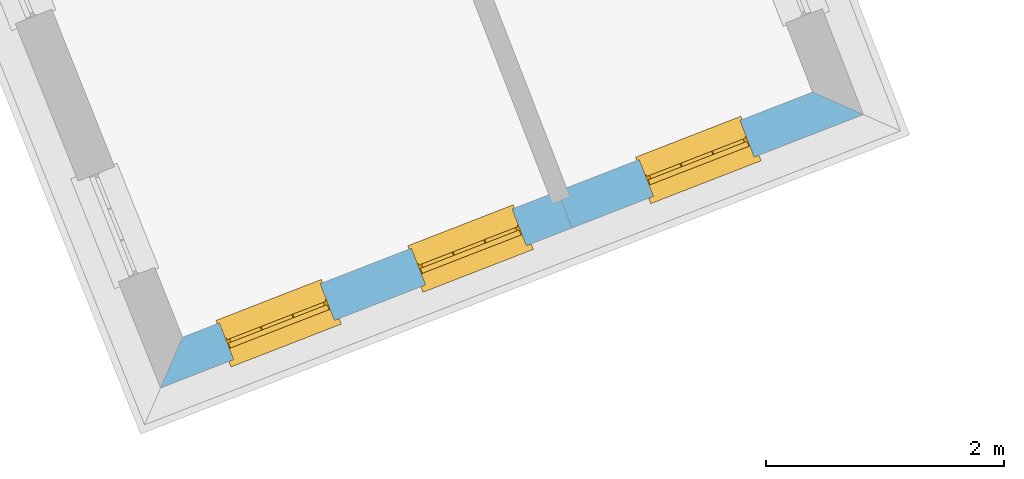
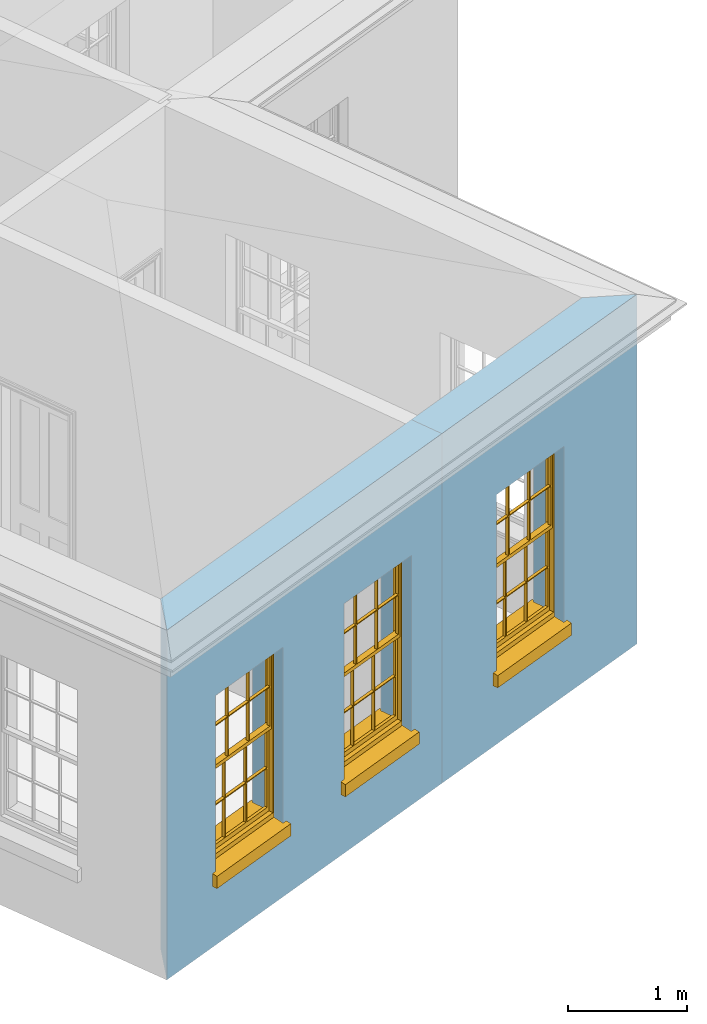
# One storey, part 3 of 11: 3 windows, 3 openings, plus 2 elements that do not belong to this part.
"""IFC2X3 building model written with IfcOpenShell, lengths in metres."""

from ifc_helpers import new_model, si_unit, frame, origin, place, context, subcontext, project, spatial, polyline, outline, extrude, faceted_brep, material, layer, layer_set, layer_usage, element, fill, save


model = new_model("IFC2X3")

# Units and contexts
model_context = context("Model", 3, world=origin())
body_context = subcontext(model_context, "Body", "Model", "MODEL_VIEW")
ifc_project = project(units=[si_unit("PLANEANGLEUNIT", "RADIAN"), si_unit("MASSUNIT", "GRAM", prefix="KILO"), si_unit("FORCEUNIT", "NEWTON", prefix="KILO"), si_unit("LENGTHUNIT", "METRE")], contexts=[model_context])

# Site, building, storey
site_placement = place(None, origin())
site = spatial("IfcSite", under=ifc_project, at=site_placement, CompositionType="ELEMENT")
building_placement = place(None, origin())
building = spatial("IfcBuilding", under=site, at=building_placement, Name="Building plot-3", CompositionType="ELEMENT")
storey_placement = place(None, frame((0.0, 0.0, 5.45)))
storey = spatial("IfcBuildingStorey", under=building, at=storey_placement, Name="Floor 1", CompositionType="ELEMENT", Elevation=5.45)

# Wall, openings, windows
ifc_material = material(Name="Masonry")
ifc_layer = layer(ifc_material, 0.33, ventilated=False)
ifc_layer_set = layer_set([ifc_layer], Name="My Wall")
ifc_layer_usage = layer_usage(ifc_layer_set, "AXIS2", "NEGATIVE", 0.08)
wall_1_placement = place(storey_placement, origin())
wall_1 = element("IfcWallStandardCase", 1, at=wall_1_placement, inside=storey, material=ifc_layer_usage, Name="exterior", context=body_context, shape_type="SweptSolid", body=[
    extrude(outline(polyline([(37.5567759813035, 41.9542826933014), (37.3715047734547, 41.5281179338397), (40.8267699200856, 42.8722782867018), (40.7071281618522, 43.1798264125078), (37.5567759813035, 41.9542826933014)])), origin(), (0.0, 0.0, 1.0), 3.6),
])
opening_1_placement = place(storey_placement, frame((0.0, 0.0, 0.75)))
opening_1 = element("IfcOpeningElement", 2, at=opening_1_placement, cuts=wall_1, Name="Opening", ObjectType="Opening", context=body_context, shape_type="SweptSolid", body=[
    extrude(outline(polyline([(37.9845234355629, 41.7665932305832), (38.8326106915735, 42.0965144426814), (38.7129689333401, 42.4040625684875), (37.8648816773295, 42.0741413563893), (37.9845234355629, 41.7665932305832)])), origin(), (0.0, 0.0, 1.0), 1.82),
])
opening_2_placement = place(storey_placement, frame((0.0, 0.0, 0.75)))
opening_2 = element("IfcOpeningElement", 3, at=opening_2_placement, cuts=wall_1, Name="Opening", ObjectType="Opening", context=body_context, shape_type="SweptSolid", body=[
    extrude(outline(polyline([(39.5966586732411, 42.3937428639628), (40.4447459292518, 42.723664076061), (40.3251041710184, 43.0312122018671), (39.4770169150077, 42.7012909897689), (39.5966586732411, 42.3937428639628)])), origin(), (0.0, 0.0, 1.0), 1.82),
])
window_1_placement = place(storey_placement, frame((37.8938857399315, 41.9995842349817, 0.75), z_axis=(0.0, 0.0, 1.0), x_axis=(0.848087256010636, 0.329921212098199, 0.0)))
window_1 = element("IfcWindow", 4, at=window_1_placement, inside=storey, Name="bedroom outside window", OverallHeight=1.82, OverallWidth=0.91, context=body_context, shape_type="Brep", held_by="IfcProductRepresentation", body=[
    faceted_brep([(0.033125, -0.105, 0.975209), (0.01, -0.105, 0.975209), (0.033125, -0.105, 1.376042), (0.876875, -0.105, 0.975209), (0.876875, -0.105, 1.376042), (0.9, -0.105, 0.975209), (0.876875, -0.105, 1.386042), (0.876875, -0.105, 1.786875), (0.9, -0.105, 1.81), (0.033125, -0.105, 1.786875), (0.033125, -0.105, 1.386042), (0.01, -0.105, 1.81), (0.876875, -0.135, 1.376042), (0.876875, -0.135, 0.975209), (0.9, -0.135, 0.937083), (0.033125, -0.135, 1.786875), (0.01, -0.135, 1.81), (0.033125, -0.135, 1.386042), (0.01, -0.135, 0.937083), (0.033125, -0.135, 0.975209), (0.033125, -0.135, 1.376042), (0.876875, -0.135, 1.786875), (0.876875, -0.135, 1.386042), (0.9, -0.135, 1.81), (0.033125, -0.105, 0.937083), (0.01, -0.105, 0.937083), (0.033125, -0.105, 0.53625), (0.876875, -0.105, 0.937083), (0.876875, -0.105, 0.53625), (0.9, -0.105, 0.937083), (0.876875, -0.105, 0.52625), (0.876875, -0.105, 0.125417), (0.9, -0.105, 0.077167), (0.033125, -0.105, 0.125417), (0.033125, -0.105, 0.52625), (0.01, -0.105, 0.077167), (-0.0425, -0.25, 0.01), (-0.0425, -0.3, 0.001667), (0.0, -0.25, 0.01), (0.9525, -0.25, 0.01), (0.91, -0.25, 0.01), (0.9525, -0.3, 0.001667), (-0.02, 0.08, 0.077167), (0.0, 0.08, 0.077167), (-0.02, 0.11, 0.077167), (0.0, -0.06, 0.077167), (0.01, -0.06, 0.077167), (0.91, -0.06, 0.077167), (0.91, 0.08, 0.077167), (0.9, -0.06, 0.077167), (0.93, 0.08, 0.077167), (0.93, 0.11, 0.077167), (0.01, -0.075, 0.975209), (0.9, -0.075, 0.975209), (0.876875, -0.075, 0.125417), (0.876875, -0.075, 0.52625), (0.9, -0.075, 0.077167), (0.876875, -0.075, 0.53625), (0.876875, -0.075, 0.937083), (0.033125, -0.075, 0.125417), (0.01, -0.075, 0.077167), (0.033125, -0.075, 0.52625), (0.033125, -0.075, 0.937083), (0.033125, -0.075, 0.53625), (-0.02, 0.08, 0.052167), (-0.02, 0.11, 0.052167), (0.93, 0.11, 0.052167), (0.93, 0.08, 0.052167), (0.91, 0.08, 0.052167), (0.0, 0.08, 0.052167), (0.91, -0.15, 0.026667), (0.0, -0.15, 0.026667), (-0.0425, -0.3, -0.123333), (0.9525, -0.3, -0.123333), (-0.0425, -0.25, -0.123333), (0.9525, -0.25, -0.123333), (0.01, -0.06, 1.81), (0.9, -0.06, 1.81), (0.0, -0.06, 1.82), (0.91, -0.06, 1.82), (0.01, -0.15, 0.077167), (0.9, -0.15, 0.077167), (0.592292, -0.105, 0.125417), (0.592292, -0.075, 0.125417), (0.317708, -0.075, 0.125417), (0.317708, -0.105, 0.125417), (0.592292, -0.105, 0.53625), (0.317708, -0.105, 0.53625), (0.317708, -0.105, 0.52625), (0.592292, -0.105, 0.52625), (0.592292, -0.075, 0.53625), (0.317708, -0.075, 0.53625), (0.592292, -0.135, 1.386042), (0.592292, -0.105, 1.386042), (0.317708, -0.105, 1.386042), (0.317708, -0.135, 1.386042), (0.317708, -0.135, 1.376042), (0.592292, -0.135, 1.376042), (0.317708, -0.105, 1.376042), (0.592292, -0.105, 1.376042), (0.602292, -0.135, 1.376042), (0.592292, -0.135, 0.975209), (0.602292, -0.135, 0.975209), (0.602292, -0.105, 0.975209), (0.592292, -0.105, 0.975209), (0.602292, -0.105, 1.376042), (0.602292, -0.075, 0.53625), (0.602292, -0.105, 0.53625), (0.317708, -0.075, 0.52625), (0.307708, -0.075, 0.125417), (0.307708, -0.075, 0.52625), (0.602292, -0.075, 0.52625), (0.602292, -0.075, 0.125417), (0.592292, -0.075, 0.52625), (0.307708, -0.075, 0.53625), (0.317708, -0.075, 0.937083), (0.307708, -0.075, 0.937083), (0.602292, -0.075, 0.937083), (0.592292, -0.075, 0.937083), (0.307708, -0.105, 0.52625), (0.307708, -0.105, 0.125417), (0.307708, -0.105, 0.53625), (0.307708, -0.105, 0.937083), (0.592292, -0.105, 0.937083), (0.317708, -0.105, 0.937083), (0.602292, -0.105, 0.937083), (0.602292, -0.105, 0.52625), (0.602292, -0.105, 0.125417), (0.307708, -0.135, 1.386042), (0.307708, -0.135, 1.376042), (0.307708, -0.135, 0.975209), (0.317708, -0.135, 0.975209), (0.317708, -0.135, 1.786875), (0.307708, -0.135, 1.786875), (0.602292, -0.135, 1.786875), (0.592292, -0.135, 1.786875), (0.602292, -0.135, 1.386042), (0.602292, -0.105, 1.386042), (0.307708, -0.105, 1.386042), (0.307708, -0.105, 1.786875), (0.317708, -0.105, 1.786875), (0.592292, -0.105, 1.786875), (0.602292, -0.105, 1.786875), (0.307708, -0.105, 1.376042), (0.317708, -0.105, 0.975209), (0.307708, -0.105, 0.975209), (0.91, -0.15, 1.82), (0.9, -0.15, 1.81), (0.01, -0.15, 1.81), (0.0, -0.15, 1.82), (0.91, -0.25, 0.0), (0.0, -0.25, 0.0), (0.91, 0.08, 0.0), (0.0, 0.08, 0.0)], [[[0, 1, 2]], [[3, 4, 5]], [[6, 7, 8]], [[9, 10, 11]], [[12, 13, 14]], [[15, 16, 17]], [[18, 19, 20]], [[21, 22, 23]], [[24, 25, 26]], [[27, 28, 29]], [[30, 31, 32]], [[33, 34, 35]], [[14, 27, 29]], [[25, 24, 18]], [[36, 37, 38]], [[39, 40, 41]], [[42, 43, 44]], [[45, 46, 43]], [[47, 48, 49]], [[50, 51, 48]], [[1, 0, 52]], [[5, 53, 3]], [[54, 55, 56]], [[57, 58, 53]], [[59, 60, 61]], [[62, 63, 52]], [[48, 43, 46, 49]], [[51, 44, 43, 48]], [[64, 42, 44, 65]], [[65, 44, 51, 66]], [[66, 51, 50, 67]], [[65, 66, 68, 69]], [[60, 56, 49, 46]], [[70, 71, 38, 40]], [[37, 41, 40, 38]], [[37, 72, 73, 41]], [[74, 75, 73, 72]], [[8, 11, 76, 77]], [[76, 78, 79, 77]], [[32, 35, 80, 81]], [[81, 80, 71, 70]], [[82, 83, 84, 85]], [[86, 87, 88, 89]], [[86, 90, 91, 87]], [[92, 93, 94, 95]], [[92, 95, 96, 97]], [[96, 98, 99, 97]], [[100, 97, 101, 102]], [[103, 104, 99, 105]], [[97, 99, 104, 101]], [[102, 103, 105, 100]], [[28, 57, 106, 107]], [[108, 84, 109, 110]], [[111, 112, 83, 113]], [[114, 110, 61, 63]], [[90, 113, 108, 91]], [[115, 91, 114, 116]], [[117, 106, 90, 118]], [[111, 106, 57, 55]], [[119, 110, 109, 120]], [[34, 61, 110, 119]], [[89, 113, 83, 82]], [[88, 108, 113, 89]], [[85, 84, 108, 88]], [[121, 114, 63, 26]], [[122, 116, 114, 121]], [[123, 118, 90, 86]], [[87, 91, 115, 124]], [[107, 106, 117, 125]], [[126, 111, 55, 30]], [[127, 112, 111, 126]], [[126, 30, 28, 107]], [[88, 119, 120, 85]], [[126, 89, 82, 127]], [[125, 123, 86, 107]], [[121, 26, 34, 119]], [[124, 122, 121, 87]], [[128, 17, 20, 129]], [[96, 129, 130, 131]], [[132, 133, 128, 95]], [[134, 135, 92, 136]], [[100, 12, 22, 136]], [[137, 6, 4, 105]], [[94, 138, 139, 140]], [[137, 93, 141, 142]], [[99, 98, 94, 93]], [[143, 2, 10, 138]], [[144, 145, 143, 98]], [[129, 143, 145, 130]], [[20, 2, 143, 129]], [[131, 144, 98, 96]], [[128, 138, 10, 17]], [[133, 139, 138, 128]], [[135, 141, 93, 92]], [[95, 94, 140, 132]], [[22, 6, 137, 136]], [[136, 137, 142, 134]], [[100, 105, 4, 12]], [[107, 86, 89, 126]], [[106, 111, 113, 90]], [[91, 108, 110, 114]], [[87, 121, 119, 88]], [[97, 100, 136, 92]], [[129, 96, 95, 128]], [[98, 143, 138, 94]], [[105, 99, 93, 137]], [[131, 101, 104, 144]], [[124, 115, 118, 123]], [[132, 140, 141, 135]], [[120, 109, 59, 33]], [[15, 9, 139, 133]], [[134, 142, 7, 21]], [[31, 54, 112, 127]], [[36, 74, 72, 37]], [[39, 41, 73, 75]], [[18, 14, 101, 131]], [[23, 16, 132, 135]], [[83, 56, 60, 84]], [[52, 53, 118, 115]], [[53, 52, 144, 104]], [[11, 8, 141, 140]], [[14, 18, 124, 123]], [[2, 1, 11, 10]], [[8, 5, 4, 6]], [[57, 53, 56, 55]], [[60, 52, 63, 61]], [[26, 25, 35, 34]], [[32, 29, 28, 30]], [[14, 23, 22, 12]], [[18, 20, 17, 16]], [[19, 0, 2, 20]], [[17, 10, 9, 15]], [[12, 4, 3, 13]], [[21, 7, 6, 22]], [[27, 58, 57, 28]], [[30, 55, 54, 31]], [[33, 59, 61, 34]], [[26, 63, 62, 24]], [[5, 8, 77, 53]], [[76, 11, 1, 52]], [[46, 45, 78, 76]], [[49, 77, 79, 47]], [[70, 146, 147, 81]], [[71, 80, 148, 149]], [[19, 130, 145, 0]], [[102, 13, 3, 103]], [[116, 122, 24, 62]], [[29, 32, 81, 14]], [[80, 35, 25, 18]], [[60, 46, 76, 52]], [[77, 49, 56, 53]], [[23, 14, 81, 147]], [[16, 148, 80, 18]], [[35, 85, 120]], [[120, 33, 35]], [[127, 82, 32]], [[32, 31, 127]], [[32, 82, 85, 35]], [[102, 101, 14]], [[14, 13, 102]], [[18, 131, 130]], [[130, 19, 18]], [[134, 21, 23]], [[23, 135, 134]], [[16, 15, 133]], [[133, 132, 16]], [[11, 140, 139]], [[139, 9, 11]], [[142, 141, 8]], [[8, 7, 142]], [[23, 147, 148, 16]], [[146, 149, 148, 147]], [[52, 115, 116]], [[116, 62, 52]], [[118, 53, 117]], [[58, 117, 53]], [[27, 125, 117, 58]], [[56, 83, 112]], [[112, 54, 56]], [[109, 84, 60]], [[60, 59, 109]], [[125, 27, 14]], [[14, 123, 125]], [[122, 124, 18]], [[18, 24, 122]], [[145, 144, 52]], [[52, 0, 145]], [[103, 3, 53]], [[53, 104, 103]], [[79, 78, 149, 146]], [[78, 45, 71, 149]], [[146, 70, 47, 79]], [[150, 75, 74, 151]], [[68, 66, 67]], [[48, 68, 67, 50]], [[69, 64, 65]], [[42, 64, 69, 43]], [[69, 68, 152, 153]], [[70, 68, 48, 47]], [[150, 152, 68, 70]], [[43, 69, 71, 45]], [[69, 153, 151, 71]], [[152, 150, 151, 153]], [[38, 151, 74, 36]], [[71, 151, 38]], [[39, 75, 150, 40]], [[40, 150, 70]]]),
])
fill(opening_1, window_1)
window_2_placement = place(storey_placement, frame((39.5060209776098, 42.6267338683614, 0.75), z_axis=(0.0, 0.0, 1.0), x_axis=(0.848087256010636, 0.329921212098199, 0.0)))
window_2 = element("IfcWindow", 5, at=window_2_placement, inside=storey, Name="bedroom outside window", OverallHeight=1.82, OverallWidth=0.91, context=body_context, shape_type="Brep", held_by="IfcProductRepresentation", body=[
    faceted_brep([(0.033125, -0.105, 0.975209), (0.01, -0.105, 0.975209), (0.033125, -0.105, 1.376042), (0.876875, -0.105, 0.975209), (0.876875, -0.105, 1.376042), (0.9, -0.105, 0.975209), (0.876875, -0.105, 1.386042), (0.876875, -0.105, 1.786875), (0.9, -0.105, 1.81), (0.033125, -0.105, 1.786875), (0.033125, -0.105, 1.386042), (0.01, -0.105, 1.81), (0.876875, -0.135, 1.376042), (0.876875, -0.135, 0.975209), (0.9, -0.135, 0.937083), (0.033125, -0.135, 1.786875), (0.01, -0.135, 1.81), (0.033125, -0.135, 1.386042), (0.01, -0.135, 0.937083), (0.033125, -0.135, 0.975209), (0.033125, -0.135, 1.376042), (0.876875, -0.135, 1.786875), (0.876875, -0.135, 1.386042), (0.9, -0.135, 1.81), (0.033125, -0.105, 0.937083), (0.01, -0.105, 0.937083), (0.033125, -0.105, 0.53625), (0.876875, -0.105, 0.937083), (0.876875, -0.105, 0.53625), (0.9, -0.105, 0.937083), (0.876875, -0.105, 0.52625), (0.876875, -0.105, 0.125417), (0.9, -0.105, 0.077167), (0.033125, -0.105, 0.125417), (0.033125, -0.105, 0.52625), (0.01, -0.105, 0.077167), (-0.0425, -0.25, 0.01), (-0.0425, -0.3, 0.001667), (0.0, -0.25, 0.01), (0.9525, -0.25, 0.01), (0.91, -0.25, 0.01), (0.9525, -0.3, 0.001667), (-0.02, 0.08, 0.077167), (0.0, 0.08, 0.077167), (-0.02, 0.11, 0.077167), (0.0, -0.06, 0.077167), (0.01, -0.06, 0.077167), (0.91, -0.06, 0.077167), (0.91, 0.08, 0.077167), (0.9, -0.06, 0.077167), (0.93, 0.08, 0.077167), (0.93, 0.11, 0.077167), (0.01, -0.075, 0.975209), (0.9, -0.075, 0.975209), (0.876875, -0.075, 0.125417), (0.876875, -0.075, 0.52625), (0.9, -0.075, 0.077167), (0.876875, -0.075, 0.53625), (0.876875, -0.075, 0.937083), (0.033125, -0.075, 0.125417), (0.01, -0.075, 0.077167), (0.033125, -0.075, 0.52625), (0.033125, -0.075, 0.937083), (0.033125, -0.075, 0.53625), (-0.02, 0.08, 0.052167), (-0.02, 0.11, 0.052167), (0.93, 0.11, 0.052167), (0.93, 0.08, 0.052167), (0.91, 0.08, 0.052167), (0.0, 0.08, 0.052167), (0.91, -0.15, 0.026667), (0.0, -0.15, 0.026667), (-0.0425, -0.3, -0.123333), (0.9525, -0.3, -0.123333), (-0.0425, -0.25, -0.123333), (0.9525, -0.25, -0.123333), (0.01, -0.06, 1.81), (0.9, -0.06, 1.81), (0.0, -0.06, 1.82), (0.91, -0.06, 1.82), (0.01, -0.15, 0.077167), (0.9, -0.15, 0.077167), (0.592292, -0.105, 0.125417), (0.592292, -0.075, 0.125417), (0.317708, -0.075, 0.125417), (0.317708, -0.105, 0.125417), (0.592292, -0.105, 0.53625), (0.317708, -0.105, 0.53625), (0.317708, -0.105, 0.52625), (0.592292, -0.105, 0.52625), (0.592292, -0.075, 0.53625), (0.317708, -0.075, 0.53625), (0.592292, -0.135, 1.386042), (0.592292, -0.105, 1.386042), (0.317708, -0.105, 1.386042), (0.317708, -0.135, 1.386042), (0.317708, -0.135, 1.376042), (0.592292, -0.135, 1.376042), (0.317708, -0.105, 1.376042), (0.592292, -0.105, 1.376042), (0.602292, -0.135, 1.376042), (0.592292, -0.135, 0.975209), (0.602292, -0.135, 0.975209), (0.602292, -0.105, 0.975209), (0.592292, -0.105, 0.975209), (0.602292, -0.105, 1.376042), (0.602292, -0.075, 0.53625), (0.602292, -0.105, 0.53625), (0.317708, -0.075, 0.52625), (0.307708, -0.075, 0.125417), (0.307708, -0.075, 0.52625), (0.602292, -0.075, 0.52625), (0.602292, -0.075, 0.125417), (0.592292, -0.075, 0.52625), (0.307708, -0.075, 0.53625), (0.317708, -0.075, 0.937083), (0.307708, -0.075, 0.937083), (0.602292, -0.075, 0.937083), (0.592292, -0.075, 0.937083), (0.307708, -0.105, 0.52625), (0.307708, -0.105, 0.125417), (0.307708, -0.105, 0.53625), (0.307708, -0.105, 0.937083), (0.592292, -0.105, 0.937083), (0.317708, -0.105, 0.937083), (0.602292, -0.105, 0.937083), (0.602292, -0.105, 0.52625), (0.602292, -0.105, 0.125417), (0.307708, -0.135, 1.386042), (0.307708, -0.135, 1.376042), (0.307708, -0.135, 0.975209), (0.317708, -0.135, 0.975209), (0.317708, -0.135, 1.786875), (0.307708, -0.135, 1.786875), (0.602292, -0.135, 1.786875), (0.592292, -0.135, 1.786875), (0.602292, -0.135, 1.386042), (0.602292, -0.105, 1.386042), (0.307708, -0.105, 1.386042), (0.307708, -0.105, 1.786875), (0.317708, -0.105, 1.786875), (0.592292, -0.105, 1.786875), (0.602292, -0.105, 1.786875), (0.307708, -0.105, 1.376042), (0.317708, -0.105, 0.975209), (0.307708, -0.105, 0.975209), (0.91, -0.15, 1.82), (0.9, -0.15, 1.81), (0.01, -0.15, 1.81), (0.0, -0.15, 1.82), (0.91, -0.25, 0.0), (0.0, -0.25, 0.0), (0.91, 0.08, 0.0), (0.0, 0.08, 0.0)], [[[0, 1, 2]], [[3, 4, 5]], [[6, 7, 8]], [[9, 10, 11]], [[12, 13, 14]], [[15, 16, 17]], [[18, 19, 20]], [[21, 22, 23]], [[24, 25, 26]], [[27, 28, 29]], [[30, 31, 32]], [[33, 34, 35]], [[14, 27, 29]], [[25, 24, 18]], [[36, 37, 38]], [[39, 40, 41]], [[42, 43, 44]], [[45, 46, 43]], [[47, 48, 49]], [[50, 51, 48]], [[1, 0, 52]], [[5, 53, 3]], [[54, 55, 56]], [[57, 58, 53]], [[59, 60, 61]], [[62, 63, 52]], [[48, 43, 46, 49]], [[51, 44, 43, 48]], [[64, 42, 44, 65]], [[65, 44, 51, 66]], [[66, 51, 50, 67]], [[65, 66, 68, 69]], [[60, 56, 49, 46]], [[70, 71, 38, 40]], [[37, 41, 40, 38]], [[37, 72, 73, 41]], [[74, 75, 73, 72]], [[8, 11, 76, 77]], [[76, 78, 79, 77]], [[32, 35, 80, 81]], [[81, 80, 71, 70]], [[82, 83, 84, 85]], [[86, 87, 88, 89]], [[86, 90, 91, 87]], [[92, 93, 94, 95]], [[92, 95, 96, 97]], [[96, 98, 99, 97]], [[100, 97, 101, 102]], [[103, 104, 99, 105]], [[97, 99, 104, 101]], [[102, 103, 105, 100]], [[28, 57, 106, 107]], [[108, 84, 109, 110]], [[111, 112, 83, 113]], [[114, 110, 61, 63]], [[90, 113, 108, 91]], [[115, 91, 114, 116]], [[117, 106, 90, 118]], [[111, 106, 57, 55]], [[119, 110, 109, 120]], [[34, 61, 110, 119]], [[89, 113, 83, 82]], [[88, 108, 113, 89]], [[85, 84, 108, 88]], [[121, 114, 63, 26]], [[122, 116, 114, 121]], [[123, 118, 90, 86]], [[87, 91, 115, 124]], [[107, 106, 117, 125]], [[126, 111, 55, 30]], [[127, 112, 111, 126]], [[126, 30, 28, 107]], [[88, 119, 120, 85]], [[126, 89, 82, 127]], [[125, 123, 86, 107]], [[121, 26, 34, 119]], [[124, 122, 121, 87]], [[128, 17, 20, 129]], [[96, 129, 130, 131]], [[132, 133, 128, 95]], [[134, 135, 92, 136]], [[100, 12, 22, 136]], [[137, 6, 4, 105]], [[94, 138, 139, 140]], [[137, 93, 141, 142]], [[99, 98, 94, 93]], [[143, 2, 10, 138]], [[144, 145, 143, 98]], [[129, 143, 145, 130]], [[20, 2, 143, 129]], [[131, 144, 98, 96]], [[128, 138, 10, 17]], [[133, 139, 138, 128]], [[135, 141, 93, 92]], [[95, 94, 140, 132]], [[22, 6, 137, 136]], [[136, 137, 142, 134]], [[100, 105, 4, 12]], [[107, 86, 89, 126]], [[106, 111, 113, 90]], [[91, 108, 110, 114]], [[87, 121, 119, 88]], [[97, 100, 136, 92]], [[129, 96, 95, 128]], [[98, 143, 138, 94]], [[105, 99, 93, 137]], [[131, 101, 104, 144]], [[124, 115, 118, 123]], [[132, 140, 141, 135]], [[120, 109, 59, 33]], [[15, 9, 139, 133]], [[134, 142, 7, 21]], [[31, 54, 112, 127]], [[36, 74, 72, 37]], [[39, 41, 73, 75]], [[18, 14, 101, 131]], [[23, 16, 132, 135]], [[83, 56, 60, 84]], [[52, 53, 118, 115]], [[53, 52, 144, 104]], [[11, 8, 141, 140]], [[14, 18, 124, 123]], [[2, 1, 11, 10]], [[8, 5, 4, 6]], [[57, 53, 56, 55]], [[60, 52, 63, 61]], [[26, 25, 35, 34]], [[32, 29, 28, 30]], [[14, 23, 22, 12]], [[18, 20, 17, 16]], [[19, 0, 2, 20]], [[17, 10, 9, 15]], [[12, 4, 3, 13]], [[21, 7, 6, 22]], [[27, 58, 57, 28]], [[30, 55, 54, 31]], [[33, 59, 61, 34]], [[26, 63, 62, 24]], [[5, 8, 77, 53]], [[76, 11, 1, 52]], [[46, 45, 78, 76]], [[49, 77, 79, 47]], [[70, 146, 147, 81]], [[71, 80, 148, 149]], [[19, 130, 145, 0]], [[102, 13, 3, 103]], [[116, 122, 24, 62]], [[29, 32, 81, 14]], [[80, 35, 25, 18]], [[60, 46, 76, 52]], [[77, 49, 56, 53]], [[23, 14, 81, 147]], [[16, 148, 80, 18]], [[35, 85, 120]], [[120, 33, 35]], [[127, 82, 32]], [[32, 31, 127]], [[32, 82, 85, 35]], [[102, 101, 14]], [[14, 13, 102]], [[18, 131, 130]], [[130, 19, 18]], [[134, 21, 23]], [[23, 135, 134]], [[16, 15, 133]], [[133, 132, 16]], [[11, 140, 139]], [[139, 9, 11]], [[142, 141, 8]], [[8, 7, 142]], [[23, 147, 148, 16]], [[146, 149, 148, 147]], [[52, 115, 116]], [[116, 62, 52]], [[118, 53, 117]], [[58, 117, 53]], [[27, 125, 117, 58]], [[56, 83, 112]], [[112, 54, 56]], [[109, 84, 60]], [[60, 59, 109]], [[125, 27, 14]], [[14, 123, 125]], [[122, 124, 18]], [[18, 24, 122]], [[145, 144, 52]], [[52, 0, 145]], [[103, 3, 53]], [[53, 104, 103]], [[79, 78, 149, 146]], [[78, 45, 71, 149]], [[146, 70, 47, 79]], [[150, 75, 74, 151]], [[68, 66, 67]], [[48, 68, 67, 50]], [[69, 64, 65]], [[42, 64, 69, 43]], [[69, 68, 152, 153]], [[70, 68, 48, 47]], [[150, 152, 68, 70]], [[43, 69, 71, 45]], [[69, 153, 151, 71]], [[152, 150, 151, 153]], [[38, 151, 74, 36]], [[71, 151, 38]], [[39, 75, 150, 40]], [[40, 150, 70]]]),
])
fill(opening_2, window_2)

# Wall, opening, window
wall_2_placement = place(storey_placement, origin())
wall_2 = element("IfcWallStandardCase", 6, at=wall_2_placement, inside=storey, material=ifc_layer_usage, Name="exterior", context=body_context, shape_type="SweptSolid", body=[
    extrude(outline(polyline([(40.7071281618522, 43.1798264125078), (40.8267699200856, 42.8722782867018), (43.2748569635184, 43.8246282235355), (42.8476670794789, 44.0125345911082), (40.7071281618522, 43.1798264125078)])), origin(), (0.0, 0.0, 1.0), 3.6),
])
opening_3_placement = place(storey_placement, frame((0.0, 0.0, 0.75)))
opening_3 = element("IfcOpeningElement", 7, at=opening_3_placement, cuts=wall_2, Name="Opening", ObjectType="Opening", context=body_context, shape_type="SweptSolid", body=[
    extrude(outline(polyline([(41.5102743115974, 43.1381738012539), (42.358361567608, 43.4680950133521), (42.2387198093746, 43.7756431391581), (41.390632553364, 43.4457219270599), (41.5102743115974, 43.1381738012539)])), origin(), (0.0, 0.0, 1.0), 1.82),
])
window_3_placement = place(storey_placement, frame((41.419636615966, 43.3711648056524, 0.75), z_axis=(0.0, 0.0, 1.0), x_axis=(0.848087256010636, 0.329921212098199, 0.0)))
window_3 = element("IfcWindow", 8, at=window_3_placement, inside=storey, Name="circulation outside window", OverallHeight=1.82, OverallWidth=0.91, context=body_context, shape_type="Brep", held_by="IfcProductRepresentation", body=[
    faceted_brep([(0.033125, -0.105, 0.975209), (0.01, -0.105, 0.975209), (0.033125, -0.105, 1.376042), (0.876875, -0.105, 0.975209), (0.876875, -0.105, 1.376042), (0.9, -0.105, 0.975209), (0.876875, -0.105, 1.386042), (0.876875, -0.105, 1.786875), (0.9, -0.105, 1.81), (0.033125, -0.105, 1.786875), (0.033125, -0.105, 1.386042), (0.01, -0.105, 1.81), (0.876875, -0.135, 1.376042), (0.876875, -0.135, 0.975209), (0.9, -0.135, 0.937083), (0.033125, -0.135, 1.786875), (0.01, -0.135, 1.81), (0.033125, -0.135, 1.386042), (0.01, -0.135, 0.937083), (0.033125, -0.135, 0.975209), (0.033125, -0.135, 1.376042), (0.876875, -0.135, 1.786875), (0.876875, -0.135, 1.386042), (0.9, -0.135, 1.81), (0.033125, -0.105, 0.937083), (0.01, -0.105, 0.937083), (0.033125, -0.105, 0.53625), (0.876875, -0.105, 0.937083), (0.876875, -0.105, 0.53625), (0.9, -0.105, 0.937083), (0.876875, -0.105, 0.52625), (0.876875, -0.105, 0.125417), (0.9, -0.105, 0.077167), (0.033125, -0.105, 0.125417), (0.033125, -0.105, 0.52625), (0.01, -0.105, 0.077167), (-0.0425, -0.25, 0.01), (-0.0425, -0.3, 0.001667), (0.0, -0.25, 0.01), (0.9525, -0.25, 0.01), (0.91, -0.25, 0.01), (0.9525, -0.3, 0.001667), (-0.02, 0.08, 0.077167), (0.0, 0.08, 0.077167), (-0.02, 0.11, 0.077167), (0.0, -0.06, 0.077167), (0.01, -0.06, 0.077167), (0.91, -0.06, 0.077167), (0.91, 0.08, 0.077167), (0.9, -0.06, 0.077167), (0.93, 0.08, 0.077167), (0.93, 0.11, 0.077167), (0.01, -0.075, 0.975209), (0.9, -0.075, 0.975209), (0.876875, -0.075, 0.125417), (0.876875, -0.075, 0.52625), (0.9, -0.075, 0.077167), (0.876875, -0.075, 0.53625), (0.876875, -0.075, 0.937083), (0.033125, -0.075, 0.125417), (0.01, -0.075, 0.077167), (0.033125, -0.075, 0.52625), (0.033125, -0.075, 0.937083), (0.033125, -0.075, 0.53625), (-0.02, 0.08, 0.052167), (-0.02, 0.11, 0.052167), (0.93, 0.11, 0.052167), (0.93, 0.08, 0.052167), (0.91, 0.08, 0.052167), (0.0, 0.08, 0.052167), (0.91, -0.15, 0.026667), (0.0, -0.15, 0.026667), (-0.0425, -0.3, -0.123333), (0.9525, -0.3, -0.123333), (-0.0425, -0.25, -0.123333), (0.9525, -0.25, -0.123333), (0.01, -0.06, 1.81), (0.9, -0.06, 1.81), (0.0, -0.06, 1.82), (0.91, -0.06, 1.82), (0.01, -0.15, 0.077167), (0.9, -0.15, 0.077167), (0.592292, -0.105, 0.125417), (0.592292, -0.075, 0.125417), (0.317708, -0.075, 0.125417), (0.317708, -0.105, 0.125417), (0.592292, -0.105, 0.53625), (0.317708, -0.105, 0.53625), (0.317708, -0.105, 0.52625), (0.592292, -0.105, 0.52625), (0.592292, -0.075, 0.53625), (0.317708, -0.075, 0.53625), (0.592292, -0.135, 1.386042), (0.592292, -0.105, 1.386042), (0.317708, -0.105, 1.386042), (0.317708, -0.135, 1.386042), (0.317708, -0.135, 1.376042), (0.592292, -0.135, 1.376042), (0.317708, -0.105, 1.376042), (0.592292, -0.105, 1.376042), (0.602292, -0.135, 1.376042), (0.592292, -0.135, 0.975209), (0.602292, -0.135, 0.975209), (0.602292, -0.105, 0.975209), (0.592292, -0.105, 0.975209), (0.602292, -0.105, 1.376042), (0.602292, -0.075, 0.53625), (0.602292, -0.105, 0.53625), (0.317708, -0.075, 0.52625), (0.307708, -0.075, 0.125417), (0.307708, -0.075, 0.52625), (0.602292, -0.075, 0.52625), (0.602292, -0.075, 0.125417), (0.592292, -0.075, 0.52625), (0.307708, -0.075, 0.53625), (0.317708, -0.075, 0.937083), (0.307708, -0.075, 0.937083), (0.602292, -0.075, 0.937083), (0.592292, -0.075, 0.937083), (0.307708, -0.105, 0.52625), (0.307708, -0.105, 0.125417), (0.307708, -0.105, 0.53625), (0.307708, -0.105, 0.937083), (0.592292, -0.105, 0.937083), (0.317708, -0.105, 0.937083), (0.602292, -0.105, 0.937083), (0.602292, -0.105, 0.52625), (0.602292, -0.105, 0.125417), (0.307708, -0.135, 1.386042), (0.307708, -0.135, 1.376042), (0.307708, -0.135, 0.975209), (0.317708, -0.135, 0.975209), (0.317708, -0.135, 1.786875), (0.307708, -0.135, 1.786875), (0.602292, -0.135, 1.786875), (0.592292, -0.135, 1.786875), (0.602292, -0.135, 1.386042), (0.602292, -0.105, 1.386042), (0.307708, -0.105, 1.386042), (0.307708, -0.105, 1.786875), (0.317708, -0.105, 1.786875), (0.592292, -0.105, 1.786875), (0.602292, -0.105, 1.786875), (0.307708, -0.105, 1.376042), (0.317708, -0.105, 0.975209), (0.307708, -0.105, 0.975209), (0.91, -0.15, 1.82), (0.9, -0.15, 1.81), (0.01, -0.15, 1.81), (0.0, -0.15, 1.82), (0.91, -0.25, 0.0), (0.0, -0.25, 0.0), (0.91, 0.08, 0.0), (0.0, 0.08, 0.0)], [[[0, 1, 2]], [[3, 4, 5]], [[6, 7, 8]], [[9, 10, 11]], [[12, 13, 14]], [[15, 16, 17]], [[18, 19, 20]], [[21, 22, 23]], [[24, 25, 26]], [[27, 28, 29]], [[30, 31, 32]], [[33, 34, 35]], [[14, 27, 29]], [[25, 24, 18]], [[36, 37, 38]], [[39, 40, 41]], [[42, 43, 44]], [[45, 46, 43]], [[47, 48, 49]], [[50, 51, 48]], [[1, 0, 52]], [[5, 53, 3]], [[54, 55, 56]], [[57, 58, 53]], [[59, 60, 61]], [[62, 63, 52]], [[48, 43, 46, 49]], [[51, 44, 43, 48]], [[64, 42, 44, 65]], [[65, 44, 51, 66]], [[66, 51, 50, 67]], [[65, 66, 68, 69]], [[60, 56, 49, 46]], [[70, 71, 38, 40]], [[37, 41, 40, 38]], [[37, 72, 73, 41]], [[74, 75, 73, 72]], [[8, 11, 76, 77]], [[76, 78, 79, 77]], [[32, 35, 80, 81]], [[81, 80, 71, 70]], [[82, 83, 84, 85]], [[86, 87, 88, 89]], [[86, 90, 91, 87]], [[92, 93, 94, 95]], [[92, 95, 96, 97]], [[96, 98, 99, 97]], [[100, 97, 101, 102]], [[103, 104, 99, 105]], [[97, 99, 104, 101]], [[102, 103, 105, 100]], [[28, 57, 106, 107]], [[108, 84, 109, 110]], [[111, 112, 83, 113]], [[114, 110, 61, 63]], [[90, 113, 108, 91]], [[115, 91, 114, 116]], [[117, 106, 90, 118]], [[111, 106, 57, 55]], [[119, 110, 109, 120]], [[34, 61, 110, 119]], [[89, 113, 83, 82]], [[88, 108, 113, 89]], [[85, 84, 108, 88]], [[121, 114, 63, 26]], [[122, 116, 114, 121]], [[123, 118, 90, 86]], [[87, 91, 115, 124]], [[107, 106, 117, 125]], [[126, 111, 55, 30]], [[127, 112, 111, 126]], [[126, 30, 28, 107]], [[88, 119, 120, 85]], [[126, 89, 82, 127]], [[125, 123, 86, 107]], [[121, 26, 34, 119]], [[124, 122, 121, 87]], [[128, 17, 20, 129]], [[96, 129, 130, 131]], [[132, 133, 128, 95]], [[134, 135, 92, 136]], [[100, 12, 22, 136]], [[137, 6, 4, 105]], [[94, 138, 139, 140]], [[137, 93, 141, 142]], [[99, 98, 94, 93]], [[143, 2, 10, 138]], [[144, 145, 143, 98]], [[129, 143, 145, 130]], [[20, 2, 143, 129]], [[131, 144, 98, 96]], [[128, 138, 10, 17]], [[133, 139, 138, 128]], [[135, 141, 93, 92]], [[95, 94, 140, 132]], [[22, 6, 137, 136]], [[136, 137, 142, 134]], [[100, 105, 4, 12]], [[107, 86, 89, 126]], [[106, 111, 113, 90]], [[91, 108, 110, 114]], [[87, 121, 119, 88]], [[97, 100, 136, 92]], [[129, 96, 95, 128]], [[98, 143, 138, 94]], [[105, 99, 93, 137]], [[131, 101, 104, 144]], [[124, 115, 118, 123]], [[132, 140, 141, 135]], [[120, 109, 59, 33]], [[15, 9, 139, 133]], [[134, 142, 7, 21]], [[31, 54, 112, 127]], [[36, 74, 72, 37]], [[39, 41, 73, 75]], [[18, 14, 101, 131]], [[23, 16, 132, 135]], [[83, 56, 60, 84]], [[52, 53, 118, 115]], [[53, 52, 144, 104]], [[11, 8, 141, 140]], [[14, 18, 124, 123]], [[2, 1, 11, 10]], [[8, 5, 4, 6]], [[57, 53, 56, 55]], [[60, 52, 63, 61]], [[26, 25, 35, 34]], [[32, 29, 28, 30]], [[14, 23, 22, 12]], [[18, 20, 17, 16]], [[19, 0, 2, 20]], [[17, 10, 9, 15]], [[12, 4, 3, 13]], [[21, 7, 6, 22]], [[27, 58, 57, 28]], [[30, 55, 54, 31]], [[33, 59, 61, 34]], [[26, 63, 62, 24]], [[5, 8, 77, 53]], [[76, 11, 1, 52]], [[46, 45, 78, 76]], [[49, 77, 79, 47]], [[70, 146, 147, 81]], [[71, 80, 148, 149]], [[19, 130, 145, 0]], [[102, 13, 3, 103]], [[116, 122, 24, 62]], [[29, 32, 81, 14]], [[80, 35, 25, 18]], [[60, 46, 76, 52]], [[77, 49, 56, 53]], [[23, 14, 81, 147]], [[16, 148, 80, 18]], [[35, 85, 120]], [[120, 33, 35]], [[127, 82, 32]], [[32, 31, 127]], [[32, 82, 85, 35]], [[102, 101, 14]], [[14, 13, 102]], [[18, 131, 130]], [[130, 19, 18]], [[134, 21, 23]], [[23, 135, 134]], [[16, 15, 133]], [[133, 132, 16]], [[11, 140, 139]], [[139, 9, 11]], [[142, 141, 8]], [[8, 7, 142]], [[23, 147, 148, 16]], [[146, 149, 148, 147]], [[52, 115, 116]], [[116, 62, 52]], [[118, 53, 117]], [[58, 117, 53]], [[27, 125, 117, 58]], [[56, 83, 112]], [[112, 54, 56]], [[109, 84, 60]], [[60, 59, 109]], [[125, 27, 14]], [[14, 123, 125]], [[122, 124, 18]], [[18, 24, 122]], [[145, 144, 52]], [[52, 0, 145]], [[103, 3, 53]], [[53, 104, 103]], [[79, 78, 149, 146]], [[78, 45, 71, 149]], [[146, 70, 47, 79]], [[150, 75, 74, 151]], [[68, 66, 67]], [[48, 68, 67, 50]], [[69, 64, 65]], [[42, 64, 69, 43]], [[69, 68, 152, 153]], [[70, 68, 48, 47]], [[150, 152, 68, 70]], [[43, 69, 71, 45]], [[69, 153, 151, 71]], [[152, 150, 151, 153]], [[38, 151, 74, 36]], [[71, 151, 38]], [[39, 75, 150, 40]], [[40, 150, 70]]]),
])
fill(opening_3, window_3)

save(model, "model.ifc")
